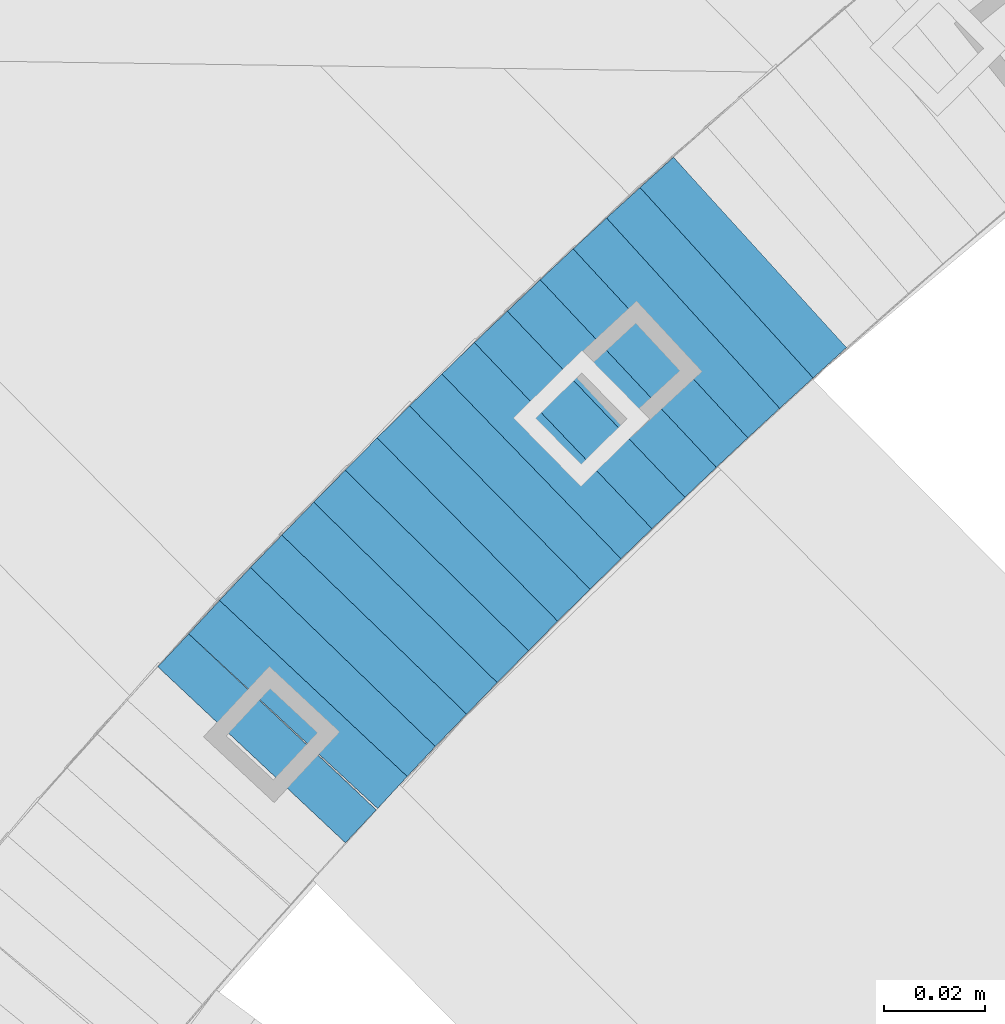
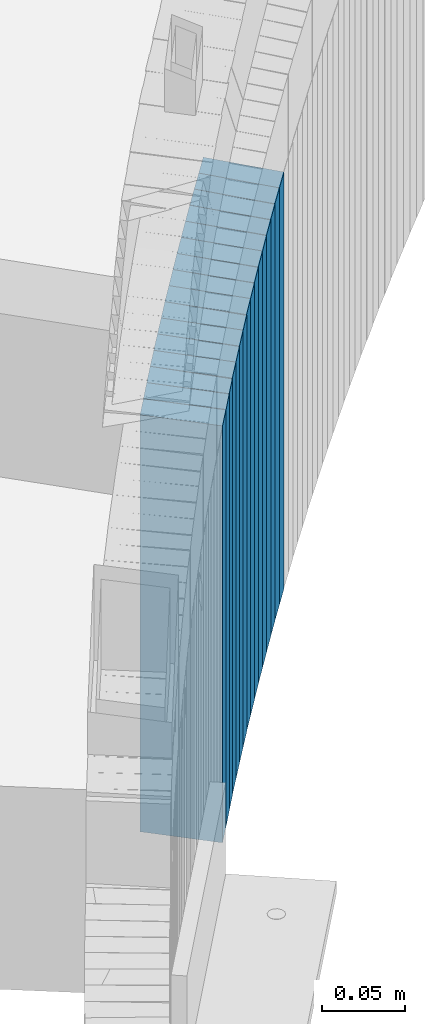
# One storey, part 898 of 975: 16 plates.
"""IFC2X3 building model written with IfcOpenShell, lengths in millimetres."""

from ifc_helpers import new_model, si_unit, frame, origin_with_axes, place, context, subcontext, project, spatial, faceted_brep, material, type_object, element, save


model = new_model("IFC2X3")

# Units and contexts
model_context = context("Model", 3, precision=1e-05, world=origin_with_axes())
body_context = subcontext(model_context, "Body", "Model", "MODEL_VIEW")
ifc_project = project(units=[si_unit("LENGTHUNIT", "METRE", prefix="MILLI"), si_unit("AREAUNIT", "SQUARE_METRE"), si_unit("VOLUMEUNIT", "CUBIC_METRE"), si_unit("MASSUNIT", "GRAM", prefix="KILO"), si_unit("TIMEUNIT", "SECOND"), si_unit("PLANEANGLEUNIT", "RADIAN"), si_unit("SOLIDANGLEUNIT", "STERADIAN"), si_unit("THERMODYNAMICTEMPERATUREUNIT", "DEGREE_CELSIUS"), si_unit("LUMINOUSINTENSITYUNIT", "LUMEN")], contexts=[model_context])

# Site, building, storey
site_placement = place(None, origin_with_axes())
site = spatial("IfcSite", under=ifc_project, at=site_placement, CompositionType="ELEMENT")
building_placement = place(site_placement, origin_with_axes())
building = spatial("IfcBuilding", under=site, at=building_placement, Name="Undefined", CompositionType="ELEMENT")
storey_placement = place(building_placement, origin_with_axes())
storey = spatial("IfcBuildingStorey", under=building, at=storey_placement, Name="Undefined", CompositionType="ELEMENT", Elevation=0.0)

# Plates
ifc_material = material(Name="STEEL/A36")
plate_type = type_object("IfcPlateType", PredefinedType="NOTDEFINED")
for number, where, z_axis, x_axis, name in (
    (1, (33797.2614508265, 4439.76307516054, 395.800000001009), (0.739940073531935, 0.672672793846723, 3.0641967896372e-10), (0.0, 0.0, -1.0), "WALL"),
    (2, (33790.6614508248, 4433.76307516042, 390.100000001014), (0.739940073531935, 0.672672793846723, 3.0641967896372e-10), (0.0, 0.0, -1.0), "WALL"),
):
    element("IfcPlate", number, at=place(storey_placement, frame(where, z_axis=z_axis, x_axis=x_axis)), inside=storey, type_object=plate_type, material=ifc_material, Name=name, context=body_context, shape_type="Brep", body=[
        faceted_brep([(0.0, -25.3999999999724, -1.81898940354586e-11), (-5.69999980926514, -25.3999999999724, 8.91964149478372), (-5.69999980926514, 25.400000000016, 8.9196414947528), (0.0, 25.3999999999869, 1.45519152283669e-11), (299.100006103516, -25.3999999999724, 8.91964149478372), (299.100006103516, 25.400000000016, 8.9196414947528), (304.799987792969, -25.3999999999724, -1.81898940354586e-11), (304.799987792969, 25.3999999999869, 1.45519152283669e-11)], [[[0, 1, 2, 3]], [[1, 4, 5, 2]], [[4, 6, 7, 5]], [[6, 0, 3, 7]], [[5, 7, 3, 2]], [[6, 4, 1, 0]]]),
    ])
plate_1_placement = place(storey_placement, frame((33784.2156114228, 4427.80438463482, 384.300000001017), z_axis=(0.734376708367177, 0.678742108762813, 2.68535359282396e-10), x_axis=(0.0, 0.0, -1.0)))
element("IfcPlate", 3, at=plate_1_placement, inside=storey, type_object=plate_type, material=ifc_material, Name="WALL", context=body_context, shape_type="Brep", body=[
    faceted_brep([(0.0, -25.3999999999724, -1.81898940354586e-11), (-5.80000019073486, -25.3999999999796, 8.98721313478018), (-5.80000019073486, 25.399999999936, 8.98721313473106), (0.0, 25.3999999999869, 1.45519152283669e-11), (299.0, -25.3999999999796, 8.98721313478018), (299.0, 25.399999999936, 8.98721313473106), (304.799987792969, -25.3999999999724, -1.81898940354586e-11), (304.799987792969, 25.3999999999869, 1.45519152283669e-11)], [[[0, 1, 2, 3]], [[1, 4, 5, 2]], [[4, 6, 7, 5]], [[6, 0, 3, 7]], [[5, 7, 3, 2]], [[6, 4, 1, 0]]]),
])
plate_2_placement = place(storey_placement, frame((33777.857142631, 4421.83619643962, 378.60000000102), z_axis=(0.729187266859689, 0.684314204039121, 4.05166247219314e-11), x_axis=(0.0, 0.0, -1.0)))
element("IfcPlate", 4, at=plate_2_placement, inside=storey, type_object=plate_type, material=ifc_material, Name="WALL", context=body_context, shape_type="Brep", body=[
    faceted_brep([(0.0, -25.3999999999724, -1.81898940354586e-11), (-5.69999980926514, -25.400000000096, 8.9140338897214), (-5.69999980926514, 25.4000000000524, 8.91403388979779), (0.0, 25.3999999999869, 1.45519152283669e-11), (299.100006103516, -25.400000000096, 8.9140338897214), (299.100006103516, 25.4000000000524, 8.91403388979779), (304.799987792969, -25.3999999999724, -1.81898940354586e-11), (304.799987792969, 25.3999999999869, 1.45519152283669e-11)], [[[0, 1, 2, 3]], [[1, 4, 5, 2]], [[4, 6, 7, 5]], [[6, 0, 3, 7]], [[5, 7, 3, 2]], [[6, 4, 1, 0]]]),
])
plate_3_placement = place(storey_placement, frame((33771.5069194478, 4415.77790392672, 372.800000001025), z_axis=(0.723608232076097, 0.690210928971503, 4.72277861263137e-11), x_axis=(0.0, 0.0, -1.0)))
element("IfcPlate", 5, at=plate_3_placement, inside=storey, type_object=plate_type, material=ifc_material, Name="WALL", context=body_context, shape_type="Brep", body=[
    faceted_brep([(0.0, -25.3999999999724, -1.81898940354586e-11), (-5.80000019073486, -25.3999999999542, 8.98276138308574), (-5.80000019073486, 25.3999999999469, 8.98276138302026), (0.0, 25.3999999999869, 1.45519152283669e-11), (299.0, -25.3999999999542, 8.98276138308574), (299.0, 25.3999999999469, 8.98276138302026), (304.799987792969, -25.3999999999724, -1.81898940354586e-11), (304.799987792969, 25.3999999999869, 1.45519152283669e-11)], [[[0, 1, 2, 3]], [[1, 4, 5, 2]], [[4, 6, 7, 5]], [[6, 0, 3, 7]], [[5, 7, 3, 2]], [[6, 4, 1, 0]]]),
])
plate_4_placement = place(storey_placement, frame((33765.0069194477, 4409.5779039266, 367.100000001028), z_axis=(0.723608232076097, 0.690210928971503, 4.72277861263137e-11), x_axis=(0.0, 0.0, -1.0)))
element("IfcPlate", 6, at=plate_4_placement, inside=storey, type_object=plate_type, material=ifc_material, Name="WALL", context=body_context, shape_type="Brep", body=[
    faceted_brep([(0.0, -25.3999999999724, -1.81898940354586e-11), (-5.69999980926514, -25.3999999999833, 8.98053455353147), (-5.69999980926514, 25.3999999999396, 8.98053455348781), (0.0, 25.3999999999869, 1.45519152283669e-11), (299.100006103516, -25.3999999999833, 8.98053455353147), (299.100006103516, 25.3999999999396, 8.98053455348781), (304.799987792969, -25.3999999999724, -1.81898940354586e-11), (304.799987792969, 25.3999999999869, 1.45519152283669e-11)], [[[0, 1, 2, 3]], [[1, 4, 5, 2]], [[4, 6, 7, 5]], [[6, 0, 3, 7]], [[5, 7, 3, 2]], [[6, 4, 1, 0]]]),
])
plate_5_placement = place(storey_placement, frame((33758.7487603335, 4403.51425136064, 361.300000001036), z_axis=(0.718240222846442, 0.695795215767897, 3.82917733077193e-11), x_axis=(0.0, 0.0, -1.0)))
element("IfcPlate", 7, at=plate_5_placement, inside=storey, type_object=plate_type, material=ifc_material, Name="WALL", context=body_context, shape_type="Brep", body=[
    faceted_brep([(0.0, -25.3999999999724, -1.81898940354586e-11), (-5.80000019073486, -25.399999999976, 8.91066741944087), (-5.80000019073486, 25.4000000000051, 8.91066741945178), (0.0, 25.3999999999869, 1.45519152283669e-11), (299.0, -25.399999999976, 8.91066741944087), (299.0, 25.4000000000051, 8.91066741945178), (304.799987792969, -25.3999999999724, -1.81898940354586e-11), (304.799987792969, 25.3999999999869, 1.45519152283669e-11)], [[[0, 1, 2, 3]], [[1, 4, 5, 2]], [[4, 6, 7, 5]], [[6, 0, 3, 7]], [[5, 7, 3, 2]], [[6, 4, 1, 0]]]),
])
for number, where, z_axis, x_axis, name in (
    (8, (33752.4941003781, 4397.35618056469, 355.600000001038), (0.712652459057462, 0.7015172646481, 1.88000512935105e-10), (0.0, 0.0, -1.0), "WALL"),
    (9, (33746.0941003768, 4391.05618056449, 349.900000001043), (0.712652459057462, 0.7015172646481, 1.88000512935105e-10), (0.0, 0.0, -1.0), "WALL"),
):
    element("IfcPlate", number, at=place(storey_placement, frame(where, z_axis=z_axis, x_axis=x_axis)), inside=storey, type_object=plate_type, material=ifc_material, Name=name, context=body_context, shape_type="Brep", body=[
        faceted_brep([(0.0, -25.3999999999724, -1.81898940354586e-11), (-5.69999980926514, -25.3999999999833, 8.98053455353147), (-5.69999980926514, 25.3999999999396, 8.98053455348781), (0.0, 25.3999999999869, 1.45519152283669e-11), (299.100006103516, -25.3999999999833, 8.98053455353147), (299.100006103516, 25.3999999999396, 8.98053455348781), (304.799987792969, -25.3999999999724, -1.81898940354586e-11), (304.799987792969, 25.3999999999869, 1.45519152283669e-11)], [[[0, 1, 2, 3]], [[1, 4, 5, 2]], [[4, 6, 7, 5]], [[6, 0, 3, 7]], [[5, 7, 3, 2]], [[6, 4, 1, 0]]]),
    ])
plate_6_placement = place(storey_placement, frame((33740.0769343055, 4384.93901449179, 344.100000001047), z_axis=(0.701517264451502, 0.712652459250988, -3.5985544855066e-10), x_axis=(0.0, 0.0, -1.0)))
element("IfcPlate", 10, at=plate_6_placement, inside=storey, type_object=plate_type, material=ifc_material, Name="WALL", context=body_context, shape_type="Brep", body=[
    faceted_brep([(0.0, -25.3999999999724, -1.81898940354586e-11), (-5.80000019073486, -25.3999999999542, 8.98276138308574), (-5.80000019073486, 25.3999999999469, 8.98276138302026), (0.0, 25.3999999999869, 1.45519152283669e-11), (299.0, -25.3999999999542, 8.98276138308574), (299.0, 25.3999999999469, 8.98276138302026), (304.799987792969, -25.3999999999724, -1.81898940354586e-11), (304.799987792969, 25.3999999999869, 1.45519152283669e-11)], [[[0, 1, 2, 3]], [[1, 4, 5, 2]], [[4, 6, 7, 5]], [[6, 0, 3, 7]], [[5, 7, 3, 2]], [[6, 4, 1, 0]]]),
])
plate_7_placement = place(storey_placement, frame((33733.8791788774, 4378.64129497967, 338.400000001051), z_axis=(0.701427481858665, 0.71274082785639, 0.0), x_axis=(0.0, 0.0, -1.0)))
element("IfcPlate", 11, at=plate_7_placement, inside=storey, type_object=plate_type, material=ifc_material, Name="WALL", context=body_context, shape_type="Brep", body=[
    faceted_brep([(0.0, -25.3999999999724, -1.81898940354586e-11), (-5.69999980926514, -25.3999999999432, 8.83911800379792), (-5.69999980926514, 25.3999999999578, 8.83911800387796), (0.0, 25.3999999999869, 1.45519152283669e-11), (299.100006103516, -25.3999999999432, 8.83911800379792), (299.100006103516, 25.3999999999578, 8.83911800387796), (304.799987792969, -25.3999999999724, -1.81898940354586e-11), (304.799987792969, 25.3999999999869, 1.45519152283669e-11)], [[[0, 1, 2, 3]], [[1, 4, 5, 2]], [[4, 6, 7, 5]], [[6, 0, 3, 7]], [[5, 7, 3, 2]], [[6, 4, 1, 0]]]),
])
plate_8_placement = place(storey_placement, frame((33727.7144808009, 4372.27983157374, 332.600000001056), z_axis=(0.695973285238861, 0.718067675246441, 0.0), x_axis=(0.0, 0.0, -1.0)))
element("IfcPlate", 12, at=plate_8_placement, inside=storey, type_object=plate_type, material=ifc_material, Name="WALL", context=body_context, shape_type="Brep", body=[
    faceted_brep([(0.0, -25.3999999999724, -1.81898940354586e-11), (-5.80000019073486, -25.3999999999869, 9.05207157135192), (-5.80000019073486, 25.3999999999796, 9.05207157134646), (0.0, 25.3999999999869, 1.45519152283669e-11), (299.0, -25.3999999999869, 9.05207157135192), (299.0, 25.3999999999796, 9.05207157134646), (304.799987792969, -25.3999999999724, -1.81898940354586e-11), (304.799987792969, 25.3999999999869, 1.45519152283669e-11)], [[[0, 1, 2, 3]], [[1, 4, 5, 2]], [[4, 6, 7, 5]], [[6, 0, 3, 7]], [[5, 7, 3, 2]], [[6, 4, 1, 0]]]),
])
plate_9_placement = place(storey_placement, frame((33721.5188635071, 4365.88435453706, 326.90000000106), z_axis=(0.695795215779443, 0.718240222835256, 1.40034899231978e-11), x_axis=(0.0, 0.0, -1.0)))
element("IfcPlate", 13, at=plate_9_placement, inside=storey, type_object=plate_type, material=ifc_material, Name="WALL", context=body_context, shape_type="Brep", body=[
    faceted_brep([(0.0, -25.3999999999724, -1.81898940354586e-11), (-5.69999980926514, -25.400000000096, 8.9140338897214), (-5.69999980926514, 25.4000000000524, 8.91403388979779), (0.0, 25.3999999999869, 1.45519152283669e-11), (299.100006103516, -25.400000000096, 8.9140338897214), (299.100006103516, 25.4000000000524, 8.91403388979779), (304.799987792969, -25.3999999999724, -1.81898940354586e-11), (304.799987792969, 25.3999999999869, 1.45519152283669e-11)], [[[0, 1, 2, 3]], [[1, 4, 5, 2]], [[4, 6, 7, 5]], [[6, 0, 3, 7]], [[5, 7, 3, 2]], [[6, 4, 1, 0]]]),
])
plate_10_placement = place(storey_placement, frame((33715.6969184274, 4359.67597223855, 321.100000001064), z_axis=(0.684314204029331, 0.729187266868878, 7.10510903445537e-11), x_axis=(0.0, 0.0, -1.0)))
element("IfcPlate", 14, at=plate_10_placement, inside=storey, type_object=plate_type, material=ifc_material, Name="WALL", context=body_context, shape_type="Brep", body=[
    faceted_brep([(0.0, -25.3999999999724, -1.81898940354586e-11), (-5.80000019073486, -25.399999999976, 8.91066741944087), (-5.80000019073486, 25.4000000000051, 8.91066741945178), (0.0, 25.3999999999869, 1.45519152283669e-11), (299.0, -25.399999999976, 8.91066741944087), (299.0, 25.4000000000051, 8.91066741945178), (304.799987792969, -25.3999999999724, -1.81898940354586e-11), (304.799987792969, 25.3999999999869, 1.45519152283669e-11)], [[[0, 1, 2, 3]], [[1, 4, 5, 2]], [[4, 6, 7, 5]], [[6, 0, 3, 7]], [[5, 7, 3, 2]], [[6, 4, 1, 0]]]),
])
plate_11_placement = place(storey_placement, frame((33709.7287302321, 4353.2175034485, 315.40000000107), z_axis=(0.678742108819367, 0.734376708314908, -2.23548340727575e-10), x_axis=(0.0, 0.0, -1.0)))
element("IfcPlate", 15, at=plate_11_placement, inside=storey, type_object=plate_type, material=ifc_material, Name="WALL", context=body_context, shape_type="Brep", body=[
    faceted_brep([(0.0, -25.3999999999724, -1.81898940354586e-11), (-5.69999980926514, -25.3999999999724, 8.9872131347729), (-5.69999980926514, 25.3999999999833, 8.98721313475835), (0.0, 25.3999999999869, 1.45519152283669e-11), (299.100006103516, -25.3999999999724, 8.9872131347729), (299.100006103516, 25.3999999999833, 8.98721313475835), (304.799987792969, -25.3999999999724, -1.81898940354586e-11), (304.799987792969, 25.3999999999869, 1.45519152283669e-11)], [[[0, 1, 2, 3]], [[1, 4, 5, 2]], [[4, 6, 7, 5]], [[6, 0, 3, 7]], [[5, 7, 3, 2]], [[6, 4, 1, 0]]]),
])
plate_12_placement = place(storey_placement, frame((33703.4969184263, 4346.57597223877, 309.700000001078), z_axis=(0.684314204029331, 0.729187266868878, 7.10510903445537e-11), x_axis=(0.0, 0.0, -1.0)))
element("IfcPlate", 16, at=plate_12_placement, inside=storey, type_object=plate_type, material=ifc_material, Name="WALL", context=body_context, shape_type="Brep", body=[
    faceted_brep([(0.0, -25.3999999999724, -1.81898940354586e-11), (-5.69999980926514, -25.400000000096, 8.9140338897214), (-5.69999980926514, 25.4000000000524, 8.91403388979779), (0.0, 25.3999999999869, 1.45519152283669e-11), (299.100006103516, -25.400000000096, 8.9140338897214), (299.100006103516, 25.4000000000524, 8.91403388979779), (304.799987792969, -25.3999999999724, -1.81898940354586e-11), (304.799987792969, 25.3999999999869, 1.45519152283669e-11)], [[[0, 1, 2, 3]], [[1, 4, 5, 2]], [[4, 6, 7, 5]], [[6, 0, 3, 7]], [[5, 7, 3, 2]], [[6, 4, 1, 0]]]),
])

save(model, "model.ifc")
